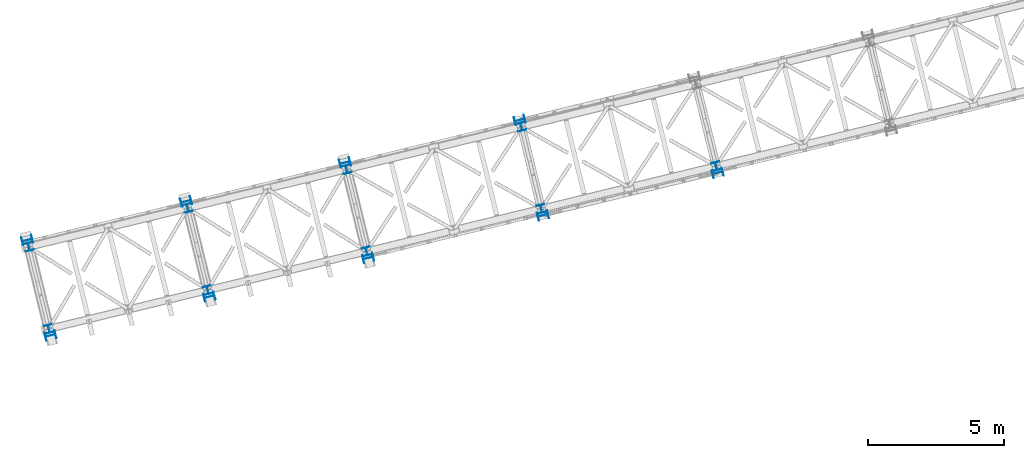
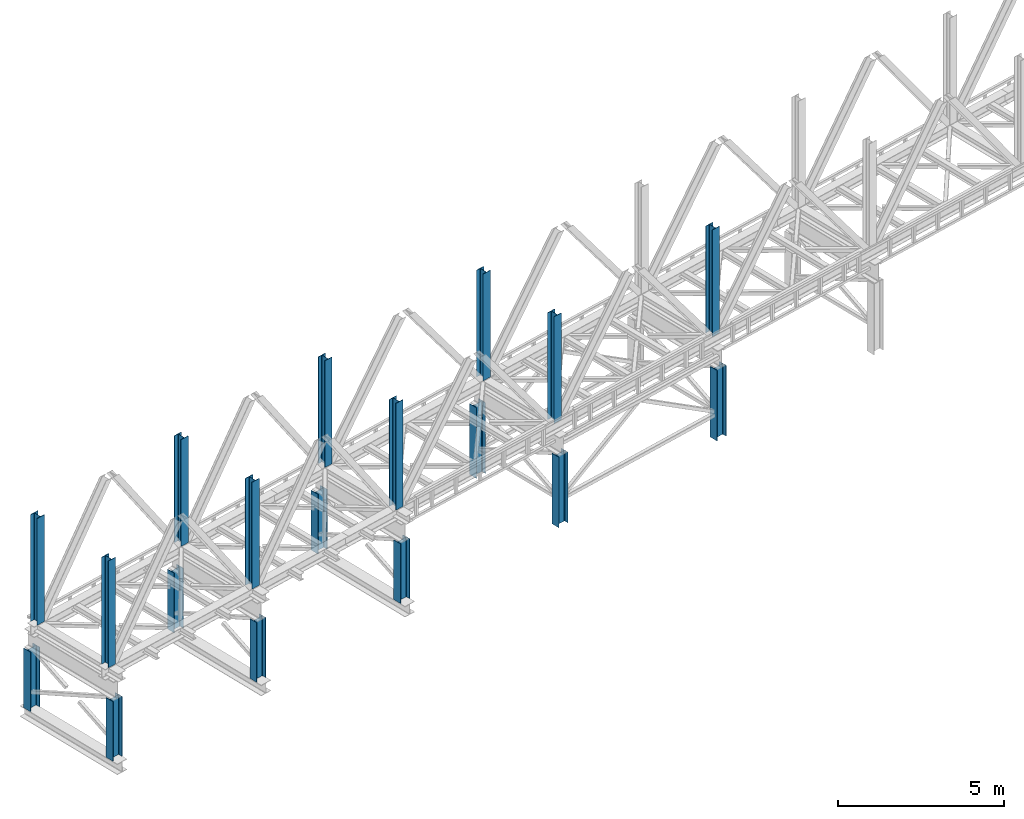
# One storey, part 1 of 92: 18 columns.
"""IFC4 building model written with IfcOpenShell, lengths in millimetres."""

import ifcopenshell
import ifcopenshell.guid

model = None  # the IFC model being written
_history = None  # IfcOwnerHistory: only IFC2X3 demands one
_inside = {}  # id of a spatial element -> (the spatial element, [elements in it])
_under = {}  # id of a project, library or spatial element -> (it, [spatial elements below it])
_declared = {}  # id of a project -> (the project, [libraries it declares])
_typed = {}  # id of a type object -> (the type object, [elements of that type])
_made_of = {}  # id of a material, layer set ... -> (it, [elements and type objects made of it])


def new_model(schema):
    """Start an empty IFC model of exactly this schema.

    Asked for "IFC4X3", IfcOpenShell would pick the latest addendum, in which some entities
    have other attributes; the version numbers below select the first issue.
    IFC2X3 requires an IfcOwnerHistory on every rooted entity: one is made here for all.
    """
    global model, _history
    if schema == "IFC4X3":
        model = ifcopenshell.file(schema_version=(4, 3, 0, 0))
    else:
        model = ifcopenshell.file(schema=schema)
    _inside.clear()
    _under.clear()
    _declared.clear()
    _typed.clear()
    _made_of.clear()
    _history = None
    if model.schema == "IFC2X3":
        org = make("IfcOrganization", Name="unknown")
        user = make(
            "IfcPersonAndOrganization",
            ThePerson=make("IfcPerson", FamilyName="unknown"),
            TheOrganization=org,
        )
        app = make(
            "IfcApplication",
            ApplicationDeveloper=org,
            Version="unknown",
            ApplicationFullName="unknown",
            ApplicationIdentifier="unknown",
        )
        _history = make(
            "IfcOwnerHistory",
            OwningUser=user,
            OwningApplication=app,
            ChangeAction="ADDED",
            CreationDate=0,
        )
    return model


def make(cls, **values):
    """One entity of the class cls with the attributes given. An attribute that is None is left unset."""
    return model.create_entity(
        cls, **{name: value for name, value in values.items() if value is not None}
    )


def entity(cls, *values):
    """Any entity or typed value of the class cls, its attributes in the order of the schema. None: left unset."""
    e = model.create_entity(cls)
    for i, value in enumerate(values):
        if value is not None:
            e[i] = value
    return e


def rooted(cls, **values):
    """An entity with a GlobalId (a new one), such as an element, a storey or a relation."""
    return make(cls, GlobalId=ifcopenshell.guid.new(), OwnerHistory=_history, **values)


def si_unit(unit_type, name, prefix=None):
    """IfcSIUnit, for example si_unit("LENGTHUNIT", "METRE", prefix="MILLI")."""
    return make("IfcSIUnit", UnitType=unit_type, Prefix=prefix, Name=name)


def converted_unit(unit_type, name, factor, base, dimensions=None, offset=None):
    """IfcConversionBasedUnit, such as the inch: factor (a typed value) times the base unit."""
    return make(
        "IfcConversionBasedUnit"
        if offset is None
        else "IfcConversionBasedUnitWithOffset",
        ConversionOffset=offset,
        Dimensions=None
        if dimensions is None
        else entity("IfcDimensionalExponents", *dimensions),
        UnitType=unit_type,
        Name=name,
        ConversionFactor=make(
            "IfcMeasureWithUnit", ValueComponent=factor, UnitComponent=base
        ),
    )


def derived_unit(unit_type, elements):
    """IfcDerivedUnit: a product of units, each with its exponent."""
    return make(
        "IfcDerivedUnit",
        Elements=[
            make("IfcDerivedUnitElement", Unit=unit, Exponent=power)
            for unit, power in elements
        ],
        UnitType=unit_type,
    )


def assignment(units):
    """IfcUnitAssignment: the units of a project."""
    return None if units is None else make("IfcUnitAssignment", Units=units)


def point(xyz):
    """IfcCartesianPoint."""
    return None if xyz is None else make("IfcCartesianPoint", Coordinates=xyz)


def direction(xyz):
    """IfcDirection."""
    return None if xyz is None else make("IfcDirection", DirectionRatios=xyz)


def frame(location, z_axis=None, x_axis=None):
    """IfcAxis2Placement3D, a coordinate frame: its origin and axes. An axis left out is left unset."""
    return make(
        "IfcAxis2Placement3D",
        Location=point(location),
        Axis=direction(z_axis),
        RefDirection=direction(x_axis),
    )


def origin():
    """The frame at (0, 0, 0) with its axes left unset."""
    return frame((0.0, 0.0, 0.0))


def place(relative_to, where):
    """IfcLocalPlacement: puts the frame where relative to a parent placement (None: the world)."""
    return make(
        "IfcLocalPlacement", PlacementRelTo=relative_to, RelativePlacement=where
    )


def context(
    kind, dimensions, precision=None, world=None, true_north=None, identifier=None
):
    """IfcGeometricRepresentationContext, for example the 3D "Model" context."""
    return make(
        "IfcGeometricRepresentationContext",
        ContextIdentifier=identifier,
        ContextType=kind,
        CoordinateSpaceDimension=dimensions,
        Precision=precision,
        WorldCoordinateSystem=world,
        TrueNorth=true_north,
    )


def subcontext(parent, identifier, kind, view, scale=None):
    """IfcGeometricRepresentationSubContext, for example "Body" below "Model"."""
    return make(
        "IfcGeometricRepresentationSubContext",
        ContextIdentifier=identifier,
        ContextType=kind,
        ParentContext=parent,
        TargetScale=scale,
        TargetView=view,
    )


def project(units=None, contexts=None):
    """IfcProject with its units and contexts."""
    return rooted(
        "IfcProject",
        Name="project",
        RepresentationContexts=contexts,
        UnitsInContext=assignment(units),
    )


def spatial(cls, under=None, at=None, **own):
    """A site, building, storey or space (cls), placed at a placement, below another one or the project."""
    s = rooted(cls, ObjectPlacement=at, **own)
    if under is not None:
        _under.setdefault(under.id(), (under, []))[1].append(s)
    return s


def point_list(points):
    """IfcCartesianPointList2D or 3D."""
    cls = (
        "IfcCartesianPointList2D" if len(points[0]) == 2 else "IfcCartesianPointList3D"
    )
    return make(cls, CoordList=points)


def indexed_curve(points, segments=None, self_intersect=None):
    """IfcIndexedPolyCurve: lines and arcs through numbered points (the first is 1)."""
    return make(
        "IfcIndexedPolyCurve",
        Points=point_list(points),
        Segments=segments,
        SelfIntersect=self_intersect,
    )


def outline(outer, holes=None, kind="AREA"):
    """IfcArbitraryClosedProfileDef: a profile drawn as a closed curve; with holes, ...WithVoids."""
    if holes is None:
        return make("IfcArbitraryClosedProfileDef", ProfileType=kind, OuterCurve=outer)
    return make(
        "IfcArbitraryProfileDefWithVoids",
        ProfileType=kind,
        OuterCurve=outer,
        InnerCurves=holes,
    )


def extrude(swept, where, along, depth):
    """IfcExtrudedAreaSolid: the profile swept, set in the frame where, extruded along a direction by depth."""
    return make(
        "IfcExtrudedAreaSolid",
        SweptArea=swept,
        Position=where,
        ExtrudedDirection=direction(along),
        Depth=depth,
    )


def shape(context_of_items, identifier, shape_type, items):
    """IfcShapeRepresentation: the items that make up one representation, for example the "Body"."""
    return make(
        "IfcShapeRepresentation",
        ContextOfItems=context_of_items,
        RepresentationIdentifier=identifier,
        RepresentationType=shape_type,
        Items=items,
    )


def made_of(thing, what):
    """Note that an element or type object is made of a material, layer set ...; save() writes the relation."""
    if what is not None:
        _made_of.setdefault(what.id(), (what, []))[1].append(thing)
    return thing


def type_object(cls, material=None, **own):
    """A type object (cls), such as IfcWallType, which elements share."""
    return made_of(rooted(cls, **own), material)


def element(
    cls,
    number,
    at=None,
    inside=None,
    cuts=None,
    type_object=None,
    material=None,
    context=None,
    identifier="Body",
    shape_type=None,
    held_by="IfcProductDefinitionShape",
    body=None,
    shapes=None,
    **own,
):
    """One element of the class cls, such as IfcWall. Its Tag is "e" and its number.

    at: its placement. inside: the storey or other place that contains it. cuts: it is an
    opening in that element (IfcRelVoidsElement). A single representation is given by context,
    identifier, shape_type and body (its items); several are given by shapes. held_by: the class
    of the entity that holds the representations. save() writes the other relations.
    """
    e = rooted(cls, Tag="e%d" % number, ObjectPlacement=at, **own)
    if body is not None:
        shapes = [shape(context, identifier, shape_type, body)]
    if shapes is not None:
        e.Representation = make(held_by, Representations=shapes)
    if inside is not None:
        _inside.setdefault(inside.id(), (inside, []))[1].append(e)
    if cuts is not None:
        rooted(
            "IfcRelVoidsElement", RelatingBuildingElement=cuts, RelatedOpeningElement=e
        )
    if type_object is not None:
        _typed.setdefault(type_object.id(), (type_object, []))[1].append(e)
    return made_of(e, material)


def aggregate(whole, parts):
    """IfcRelAggregates: a whole, such as a stair, and the parts it consists of."""
    return rooted("IfcRelAggregates", RelatingObject=whole, RelatedObjects=parts)


def save(model, path):
    """Write the relations noted so far, then the file.

    IfcRelAggregates (storeys below a building ...), IfcRelContainedInSpatialStructure (elements
    in a storey), IfcRelDefinesByType, IfcRelAssociatesMaterial and IfcRelDeclares: one each for
    every whole, place, type object, material and project.
    """
    for whole, parts in _under.values():
        aggregate(whole, parts)
    for where, things in _inside.values():
        rooted(
            "IfcRelContainedInSpatialStructure",
            RelatedElements=things,
            RelatingStructure=where,
        )
    for kind, things in _typed.values():
        rooted("IfcRelDefinesByType", RelatedObjects=things, RelatingType=kind)
    for what, things in _made_of.values():
        rooted("IfcRelAssociatesMaterial", RelatedObjects=things, RelatingMaterial=what)
    for by, libraries in _declared.values():
        rooted("IfcRelDeclares", RelatingContext=by, RelatedDefinitions=libraries)
    model.write(path)


model = new_model("IFC4")

# Units and contexts
model_context = context("Model", 3, precision=0.01, world=origin(), true_north=direction((6.12303176911189e-17, 1.0)))
plan_context = context("Plan", 3, precision=0.01, world=origin(), true_north=direction((6.12303176911189e-17, 1.0)))
body_context = subcontext(model_context, "Body", "Model", "MODEL_VIEW")
ifc_project = project(units=[si_unit("LENGTHUNIT", "METRE", prefix="MILLI"), si_unit("AREAUNIT", "SQUARE_METRE"), si_unit("VOLUMEUNIT", "CUBIC_METRE"), converted_unit("PLANEANGLEUNIT", "DEGREE", entity("IfcRatioMeasure", 0.0174532925199433), si_unit("PLANEANGLEUNIT", "RADIAN"), dimensions=[0, 0, 0, 0, 0, 0, 0]), si_unit("MASSUNIT", "GRAM", prefix="KILO"), derived_unit("MASSDENSITYUNIT", [(si_unit("MASSUNIT", "GRAM", prefix="KILO"), 1), (si_unit("LENGTHUNIT", "METRE"), -3)]), derived_unit("MOMENTOFINERTIAUNIT", [(si_unit("LENGTHUNIT", "METRE"), 4)]), si_unit("TIMEUNIT", "SECOND"), si_unit("FREQUENCYUNIT", "HERTZ"), si_unit("THERMODYNAMICTEMPERATUREUNIT", "DEGREE_CELSIUS"), derived_unit("THERMALTRANSMITTANCEUNIT", [(si_unit("MASSUNIT", "GRAM", prefix="KILO"), 1), (si_unit("THERMODYNAMICTEMPERATUREUNIT", "KELVIN"), -1), (si_unit("TIMEUNIT", "SECOND"), -3)]), derived_unit("VOLUMETRICFLOWRATEUNIT", [(si_unit("LENGTHUNIT", "METRE"), 3), (si_unit("TIMEUNIT", "SECOND"), -1)]), derived_unit("MASSFLOWRATEUNIT", [(si_unit("MASSUNIT", "GRAM", prefix="KILO"), 1), (si_unit("TIMEUNIT", "SECOND"), -1)]), derived_unit("ROTATIONALFREQUENCYUNIT", [(si_unit("TIMEUNIT", "SECOND"), -1)]), si_unit("ELECTRICCURRENTUNIT", "AMPERE"), si_unit("ELECTRICVOLTAGEUNIT", "VOLT"), si_unit("POWERUNIT", "WATT"), si_unit("FORCEUNIT", "NEWTON", prefix="KILO"), si_unit("ILLUMINANCEUNIT", "LUX"), si_unit("LUMINOUSFLUXUNIT", "LUMEN"), si_unit("LUMINOUSINTENSITYUNIT", "CANDELA"), derived_unit("USERDEFINED", [(si_unit("MASSUNIT", "GRAM", prefix="KILO"), -1), (si_unit("LENGTHUNIT", "METRE"), -2), (si_unit("TIMEUNIT", "SECOND"), 3), (si_unit("LUMINOUSFLUXUNIT", "LUMEN"), 1)]), derived_unit("LINEARVELOCITYUNIT", [(si_unit("LENGTHUNIT", "METRE"), 1), (si_unit("TIMEUNIT", "SECOND"), -1)]), si_unit("PRESSUREUNIT", "PASCAL"), derived_unit("USERDEFINED", [(si_unit("LENGTHUNIT", "METRE"), -2), (si_unit("MASSUNIT", "GRAM", prefix="KILO"), 1), (si_unit("TIMEUNIT", "SECOND"), -2)]), derived_unit("LINEARFORCEUNIT", [(si_unit("MASSUNIT", "GRAM", prefix="KILO"), 1), (si_unit("LENGTHUNIT", "METRE"), 1), (si_unit("TIMEUNIT", "SECOND"), -2), (si_unit("LENGTHUNIT", "METRE"), -1)]), derived_unit("PLANARFORCEUNIT", [(si_unit("MASSUNIT", "GRAM", prefix="KILO"), 1), (si_unit("LENGTHUNIT", "METRE"), 1), (si_unit("TIMEUNIT", "SECOND"), -2), (si_unit("LENGTHUNIT", "METRE"), -2)])], contexts=[model_context, plan_context])

# Site, building, storey
site_placement = place(None, origin())
site = spatial("IfcSite", under=ifc_project, at=site_placement, CompositionType="ELEMENT")
building_placement = place(site_placement, origin())
building = spatial("IfcBuilding", under=site, at=building_placement, CompositionType="ELEMENT")
storey_placement = place(building_placement, frame((0.0, 0.0, 15900.0)))
storey = spatial("IfcBuildingStorey", under=building, at=storey_placement, Name="05", CompositionType="ELEMENT", Elevation=15900.0)

# Columns
column_type_1 = type_object("IfcColumnType", PredefinedType="COLUMN")
placement = place(storey_placement, origin())
element("IfcColumn", 1, at=placement, inside=storey, type_object=column_type_1, ObjectType="Steel Column", PredefinedType="COLUMN", context=body_context, shape_type="SweptSolid", body=[
    extrude(outline(indexed_curve([(-196.000000000003, -149.999999999996), (-180.000000000004, -149.999999999996), (-179.999999999999, -27.7499999999967), (-178.325349715252, -19.3309644879636), (-173.556349186109, -12.1936508138919), (-166.419035512033, -7.42465028474881), (-157.999999999999, -5.74999999999698), (157.999999999996, -5.75000000000311), (166.419035512028, -7.42465028475528), (173.556349186106, -12.193650813901), (178.325349715245, -19.3309644879716), (180.000000000002, -27.7500000000052), (179.999999999998, -150.000000000004), (195.999999999997, -150.000000000005), (196.000000000003, 149.999999999995), (180.000000000003, 149.999999999995), (179.999999999999, 27.7499999999961), (178.325349715252, 19.3309644879631), (173.5563491861, 12.193650813893), (166.419035512032, 7.4246502847467), (157.999999999999, 5.74999999999646), (-157.999999999997, 5.75000000000206), (-166.419035512028, 7.4246502847537), (-173.556349186115, 12.1936508139025), (-178.325349715245, 19.3309644879711), (-180.000000000002, 27.7500000000047), (-179.999999999998, 150.000000000003), (-195.999999999997, 150.000000000004), (-196.000000000003, -149.999999999996)], self_intersect=False)), frame((-60216.44, 2665.86, 398.0), z_axis=(0.0, 0.0, 1.0), x_axis=(-0.971552058141468, -0.236826092990358, 0.0)), (0.0, 0.0, 1.0), 2197.00000000001),
])
column_type_2 = type_object("IfcColumnType", PredefinedType="COLUMN")
element("IfcColumn", 2, at=placement, inside=storey, type_object=column_type_2, ObjectType="Steel Column", PredefinedType="COLUMN", context=body_context, shape_type="SweptSolid", body=[
    extrude(outline(indexed_curve([(-196.000000000006, -150.0), (-180.000000000007, -150.0), (-180.000000000007, -27.75), (-178.32534971526, -19.3309644879674), (-173.556349186108, -12.1936508138966), (-166.419035512041, -7.42465028475223), (-158.000000000007, -5.75000000000066), (157.999999999988, -5.74999999999533), (166.419035512028, -7.42465028474928), (173.556349186099, -12.1936508138922), (178.325349715238, -19.3309644879637), (179.999999999995, -27.7499999999967), (179.999999999995, -149.999999999996), (195.999999999994, -149.999999999996), (195.99999999999, 150.000000000004), (179.99999999999, 150.000000000003), (179.99999999999, 27.7500000000041), (178.325349715243, 19.3309644879715), (173.5563491861, 12.1936508138987), (166.419035512024, 7.42465028475633), (157.99999999999, 5.75000000000371), (-158.000000000005, 5.75000000000049), (-166.419035512036, 7.42465028475133), (-173.556349186115, 12.1936508138973), (-178.325349715254, 19.3309644879689), (-180.000000000012, 27.7500000000019), (-180.000000000012, 150.0), (-196.000000000011, 150.0), (-196.000000000006, -150.0)], self_intersect=False)), frame((-61069.01, 6163.45, 398.0), z_axis=(0.0, 0.0, 1.0), x_axis=(-0.971552058141476, -0.236826092990326, 0.0)), (0.0, 0.0, 1.0), 2197.0),
])
column_type_3 = type_object("IfcColumnType", PredefinedType="COLUMN")
element("IfcColumn", 3, at=placement, inside=storey, type_object=column_type_3, ObjectType="Steel Column", PredefinedType="COLUMN", context=body_context, shape_type="SweptSolid", body=[
    extrude(outline(indexed_curve([(-196.000000000003, -149.999999999995), (-180.000000000003, -149.999999999995), (-179.999999999999, -27.7499999999956), (-178.325349715252, -19.3309644879631), (-173.556349186109, -12.1936508138909), (-166.419035512032, -7.42465028474775), (-157.999999999999, -5.74999999999646), (158.000000000005, -5.75000000000358), (166.419035512028, -7.42465028475423), (173.556349186107, -12.1936508138999), (178.325349715246, -19.3309644879706), (180.000000000003, -27.7500000000042), (179.999999999998, -150.000000000003), (195.999999999998, -150.000000000003), (196.000000000003, 149.999999999996), (180.000000000004, 149.999999999996), (179.999999999999, 27.7499999999972), (178.325349715252, 19.3309644879641), (173.5563491861, 12.193650813894), (166.419035512032, 7.42465028474775), (157.999999999999, 5.74999999999751), (-157.999999999996, 5.75000000000258), (-166.419035512028, 7.42465028475423), (-173.556349186106, 12.1936508139015), (-178.325349715245, 19.3309644879721), (-180.000000000002, 27.7500000000047), (-179.999999999998, 150.000000000004), (-195.999999999997, 150.000000000004), (-196.000000000003, -149.999999999995)], self_intersect=False)), frame((-54387.12, 4086.82, 398.0), z_axis=(0.0, 0.0, 1.0), x_axis=(-0.971552058141468, -0.236826092990358, 0.0)), (0.0, 0.0, 1.0), 2197.00000000001),
])
column_type_4 = type_object("IfcColumnType", PredefinedType="COLUMN")
element("IfcColumn", 4, at=placement, inside=storey, type_object=column_type_4, ObjectType="Steel Column", PredefinedType="COLUMN", context=body_context, shape_type="SweptSolid", body=[
    extrude(outline(indexed_curve([(-195.999999999982, -150.000000000009), (-179.999999999982, -150.000000000008), (-179.999999999982, -27.7500000000083), (-178.325349715235, -19.3309644879757), (-173.556349186092, -12.1936508139028), (-166.419035512016, -7.42465028476049), (-157.999999999982, -5.75000000000891), (158.000000000021, -5.75000000000564), (166.419035512044, -7.42465028475549), (173.556349186123, -12.1936508139004), (178.325349715262, -19.330964487972), (180.00000000002, -27.750000000005), (180.000000000019, -150.000000000004), (196.000000000019, -150.000000000004), (196.000000000014, 149.999999999996), (180.000000000015, 149.999999999995), (180.000000000015, 27.7499999999959), (178.325349715268, 19.3309644879632), (173.556349186116, 12.1936508138925), (166.419035512049, 7.42465028474807), (158.000000000015, 5.74999999999545), (-157.999999999981, 5.74999999998907), (-166.41903551202, 7.42465028474407), (-173.556349186091, 12.193650813888), (-178.325349715238, 19.3309644879605), (-179.999999999987, 27.7499999999926), (-179.999999999987, 149.999999999991), (-195.999999999986, 149.999999999991), (-195.999999999982, -150.000000000009)], self_intersect=False)), frame((-55239.7, 7584.41, 398.0), z_axis=(0.0, 0.0, 1.0), x_axis=(-0.971552058141476, -0.236826092990326, 0.0)), (0.0, 0.0, 1.0), 2197.0),
])
column_type_5 = type_object("IfcColumnType", PredefinedType="COLUMN")
element("IfcColumn", 5, at=placement, inside=storey, type_object=column_type_5, ObjectType="Steel Column", PredefinedType="COLUMN", context=body_context, shape_type="SweptSolid", body=[
    extrude(outline(indexed_curve([(-196.000000000008, -149.99999999999), (-180.000000000009, -149.99999999999), (-180.0, -27.7499999999913), (-178.325349715253, -19.3309644879588), (-173.556349186109, -12.1936508138862), (-166.419035512033, -7.42465028474332), (-157.999999999999, -5.74999999999335), (157.999999999996, -5.75000000000884), (166.419035512027, -7.42465028476128), (173.556349186106, -12.1936508139067), (178.325349715245, -19.3309644879775), (179.999999999993, -27.7500000000096), (179.999999999993, -150.000000000012), (195.999999999992, -150.000000000012), (196.000000000008, 149.999999999988), (180.000000000008, 149.999999999988), (180.0, 27.7499999999892), (178.325349715253, 19.3309644879567), (173.556349186109, 12.1936508138852), (166.419035512032, 7.42465028474122), (157.999999999998, 5.74999999999019), (-157.999999999996, 5.75000000000779), (-166.419035512028, 7.42465028475707), (-173.556349186106, 12.1936508139056), (-178.325349715245, 19.3309644879764), (-180.000000000002, 27.7500000000106), (-179.999999999993, 150.000000000011), (-195.999999999993, 150.00000000001), (-196.000000000008, -149.99999999999)], self_intersect=False)), frame((-48557.81, 5507.78, 398.0), z_axis=(0.0, 0.0, 1.0), x_axis=(-0.97155205814146, -0.23682609299039, 0.0)), (0.0, 0.0, 1.0), 2197.00000000001),
])
column_type_6 = type_object("IfcColumnType", PredefinedType="COLUMN")
element("IfcColumn", 6, at=placement, inside=storey, type_object=column_type_6, ObjectType="Steel Column", PredefinedType="COLUMN", context=body_context, shape_type="SweptSolid", body=[
    extrude(outline(indexed_curve([(-196.000000000007, -150.000000000001), (-180.000000000007, -150.000000000001), (-180.000000000007, -27.7500000000011), (-178.32534971526, -19.3309644879685), (-173.556349186117, -12.1936508138956), (-166.419035512041, -7.42465028475328), (-158.000000000007, -5.75000000000066), (157.999999999988, -5.74999999999744), (166.419035512019, -7.42465028474828), (173.556349186098, -12.1936508138932), (178.325349715237, -19.3309644879648), (179.999999999995, -27.7499999999967), (179.999999999994, -149.999999999997), (195.999999999994, -149.999999999997), (195.999999999989, 150.000000000002), (179.99999999999, 150.000000000003), (179.99999999999, 27.7500000000041), (178.325349715234, 19.3309644879725), (173.556349186091, 12.1936508138997), (166.419035512024, 7.42465028475528), (157.99999999999, 5.75000000000266), (-158.000000000005, 5.74999999999838), (-166.419035512045, 7.42465028475233), (-173.556349186116, 12.1936508138963), (-178.325349715254, 19.3309644879678), (-180.000000000012, 27.7499999999998), (-180.000000000012, 149.999999999999), (-196.000000000011, 149.999999999999), (-196.000000000007, -150.000000000001)], self_intersect=False)), frame((-49410.39, 9005.36, 398.0), z_axis=(0.0, 0.0, 1.0), x_axis=(-0.971552058141476, -0.236826092990326, 0.0)), (0.0, 0.0, 1.0), 2197.0),
])
column_type_7 = type_object("IfcColumnType", PredefinedType="COLUMN")
element("IfcColumn", 7, at=placement, inside=storey, type_object=column_type_7, ObjectType="Steel Column", PredefinedType="COLUMN", context=body_context, shape_type="SweptSolid", body=[
    extrude(outline(indexed_curve([(-196.000000000007, -150.000000000002), (-180.000000000008, -150.000000000002), (-180.000000000007, -27.7500000000032), (-178.325349715252, -19.3309644879715), (-173.556349186109, -12.1936508138987), (-166.419035512041, -7.42465028475433), (-158.000000000008, -5.75000000000275), (157.999999999996, -5.75000000000055), (166.419035512027, -7.42465028475138), (173.556349186098, -12.1936508138953), (178.325349715237, -19.3309644879658), (179.999999999994, -27.7499999999989), (179.999999999994, -149.999999999998), (195.999999999993, -149.999999999999), (195.999999999989, 150.000000000001), (179.99999999999, 150.000000000002), (179.999999999998, 27.75), (178.325349715242, 19.3309644879683), (173.556349186099, 12.1936508138955), (166.419035512023, 7.42465028475317), (157.999999999989, 5.7500000000016), (-158.000000000014, 5.74999999999939), (-166.419035512037, 7.42465028474713), (-173.556349186116, 12.1936508138931), (-178.325349715264, 19.3309644879657), (-180.000000000013, 27.7499999999966), (-180.000000000012, 149.999999999997), (-196.000000000011, 149.999999999998), (-196.000000000007, -150.000000000002)], self_intersect=False)), frame((-42145.56, 7070.83, -1.99), z_axis=(0.0, 0.0, 1.0), x_axis=(-0.971552058141476, -0.236826092990326, 0.0)), (0.0, 0.0, 1.0), 2595.99999999999),
])
column_type_8 = type_object("IfcColumnType", PredefinedType="COLUMN")
element("IfcColumn", 8, at=placement, inside=storey, type_object=column_type_8, ObjectType="Steel Column", PredefinedType="COLUMN", context=body_context, shape_type="SweptSolid", body=[
    extrude(outline(indexed_curve([(-195.999999999981, -150.000000000007), (-179.999999999982, -150.000000000007), (-179.999999999982, -27.7500000000072), (-178.325349715235, -19.3309644879746), (-173.556349186092, -12.1936508139018), (-166.419035512016, -7.42465028475944), (-157.999999999982, -5.75000000000681), (158.000000000021, -5.75000000000564), (166.419035512045, -7.42465028475443), (173.556349186124, -12.1936508138994), (178.325349715262, -19.330964487972), (180.000000000011, -27.7500000000029), (180.00000000002, -150.000000000003), (196.000000000019, -150.000000000003), (196.000000000015, 149.999999999997), (180.000000000015, 149.999999999995), (180.000000000015, 27.7499999999969), (178.32534971526, 19.3309644879663), (173.556349186125, 12.1936508138914), (166.419035512049, 7.42465028474913), (158.000000000015, 5.7499999999965), (-157.99999999998, 5.74999999999118), (-166.41903551202, 7.42465028474617), (-173.556349186091, 12.193650813887), (-178.32534971523, 19.3309644879595), (-179.999999999987, 27.7499999999926), (-179.999999999987, 149.999999999993), (-195.999999999986, 149.999999999993), (-195.999999999981, -150.000000000007)], self_intersect=False)), frame((-42998.14, 10568.42, -2.0), z_axis=(0.0, 0.0, 1.0), x_axis=(-0.971552058141476, -0.236826092990326, 0.0)), (0.0, 0.0, 1.0), 2597.00000000003),
])
column_type_9 = type_object("IfcColumnType", PredefinedType="COLUMN")
element("IfcColumn", 9, at=placement, inside=storey, type_object=column_type_9, ObjectType="Steel Column", PredefinedType="COLUMN", context=body_context, shape_type="SweptSolid", body=[
    extrude(outline(indexed_curve([(-196.000000000007, -150.000000000002), (-179.999999999999, -150.000000000002), (-180.000000000003, -27.7500000000015), (-178.325349715252, -19.3309644879699), (-173.556349186109, -12.1936508138971), (-166.419035512037, -7.4246502847527), (-158.000000000007, -5.75000000000118), (157.999999999996, -5.74999999999896), (166.419035512028, -7.42465028475089), (173.556349186103, -12.1936508138948), (178.325349715246, -19.3309644879664), (179.999999999995, -27.7499999999984), (179.999999999994, -149.999999999999), (196.000000000002, -149.999999999999), (195.999999999999, 150.000000000002), (179.99999999999, 150.000000000002), (179.999999999994, 27.7500000000014), (178.325349715243, 19.3309644879698), (173.5563491861, 12.193650813897), (166.419035512028, 7.42465028475265), (157.999999999994, 5.7500000000011), (-158.000000000005, 5.74999999999997), (-166.419035512036, 7.42465028475294), (-173.556349186107, 12.1936508138948), (-178.325349715254, 19.3309644879684), (-180.000000000008, 27.7499999999994), (-180.000000000002, 150.000000000001), (-196.000000000011, 149.999999999999), (-196.000000000007, -150.000000000002)], self_intersect=False)), frame((-35733.32, 8633.88, -1.99), z_axis=(0.0, 0.0, 1.0), x_axis=(-0.971552058141475, -0.23682609299033, 0.0)), (0.0, 0.0, 1.0), 2596.99999999999),
])
column_type_10 = type_object("IfcColumnType", PredefinedType="COLUMN")
element("IfcColumn", 10, at=placement, inside=storey, type_object=column_type_10, ObjectType="Steel Column", PredefinedType="COLUMN", context=body_context, shape_type="SweptSolid", body=[
    extrude(outline(indexed_curve([(-149.999999999947, -150.00000000004), (-134.499999999948, -150.00000000004), (-134.499999999989, -23.000000000035), (-133.129831585195, -16.1116982174633), (-129.227922061352, -10.2720779386778), (-123.388301782567, -6.37016841483106), (-116.499999999995, -5.00000000002753), (116.500000000005, -4.99999999995134), (123.388301782576, -6.37016841475037), (129.227922061364, -10.2720779385883), (133.129831585211, -16.1116982173765), (134.500000000009, -22.9999999999507), (134.500000000052, -149.999999999947), (150.000000000053, -149.999999999939), (149.999999999952, 150.000000000057), (134.499999999953, 150.000000000057), (134.499999999994, 23.0000000000515), (133.1298315852, 16.11169821748), (129.227922061357, 10.2720779386945), (123.388301782573, 6.37016841484763), (116.5, 5.0000000000441), (-116.499999999999, 4.99999999996792), (-123.388301782572, 6.3701684147584), (-129.227922061359, 10.272077938605), (-133.129831585207, 16.1116982173846), (-134.500000000006, 22.9999999999588), (-134.500000000047, 149.999999999964), (-150.000000000048, 149.999999999956), (-149.999999999947, -150.00000000004)], self_intersect=False)), frame((-60275.64, 2908.75, 3685.0), z_axis=(0.0, 0.0, 1.0), x_axis=(-0.236826092990013, 0.971552058141552, 0.0)), (0.0, 0.0, 1.0), 3931.00000000001),
])
column_type_11 = type_object("IfcColumnType", PredefinedType="COLUMN")
element("IfcColumn", 11, at=placement, inside=storey, type_object=column_type_11, ObjectType="Steel Column", PredefinedType="COLUMN", context=body_context, shape_type="SweptSolid", body=[
    extrude(outline(indexed_curve([(-149.999999999951, -150.000000000048), (-134.499999999952, -150.000000000048), (-134.499999999993, -23.0000000000429), (-133.129831585199, -16.1116982174712), (-129.227922061356, -10.2720779386857), (-123.388301782572, -6.37016841483897), (-116.499999999999, -5.00000000003544), (116.5, -4.99999999995924), (123.388301782572, -6.37016841475827), (129.22792206136, -10.2720779385963), (133.129831585206, -16.1116982173844), (134.500000000005, -22.9999999999586), (134.500000000048, -149.999999999955), (150.000000000049, -149.999999999947), (149.999999999948, 150.000000000049), (134.499999999949, 150.000000000049), (134.49999999999, 23.0000000000436), (133.129831585196, 16.111698217472), (129.227922061353, 10.2720779386865), (123.388301782569, 6.37016841483961), (116.499999999996, 5.00000000003607), (-116.500000000003, 4.99999999995975), (-123.388301782576, 6.37016841475036), (-129.227922061362, 10.2720779385968), (-133.129831585211, 16.1116982173766), (-134.500000000009, 22.9999999999507), (-134.500000000048, 149.999999999964), (-150.000000000052, 149.999999999948), (-149.999999999951, -150.000000000048)], self_intersect=False)), frame((-54446.33, 4329.71, 3685.0), z_axis=(0.0, 0.0, 1.0), x_axis=(-0.236826092990013, 0.971552058141552, 0.0)), (0.0, 0.0, 1.0), 3931.00000000001),
])
column_type_12 = type_object("IfcColumnType", PredefinedType="COLUMN")
element("IfcColumn", 12, at=placement, inside=storey, type_object=column_type_12, ObjectType="Steel Column", PredefinedType="COLUMN", context=body_context, shape_type="SweptSolid", body=[
    extrude(outline(indexed_curve([(-150.000000000031, -149.999999999977), (-134.50000000003, -149.999999999977), (-134.500000000005, -22.9999999999802), (-133.129831585207, -16.1116982174091), (-129.227922061359, -10.2720779386173), (-123.388301782573, -6.37016841477337), (-116.500000000001, -4.99999999998207), (116.499999999999, -5.00000000003072), (123.38830178257, -6.37016841482463), (129.227922061355, -10.2720779386745), (133.1298315852, -16.1116982174562), (134.499999999995, -23.0000000000312), (134.49999999997, -150.000000000028), (149.999999999969, -150.000000000036), (150.00000000003, 149.999999999968), (134.500000000029, 149.999999999968), (134.500000000006, 22.999999999971), (133.129831585206, 16.1116982174004), (129.227922061359, 10.2720779386083), (123.388301782573, 6.37016841477337), (116.5, 4.99999999997339), (-116.500000000001, 5.00000000001338), (-123.388301782574, 6.3701684148078), (-129.227922061357, 10.2720779386571), (-133.129831585203, 16.1116982174391), (-134.499999999998, 23.0000000000141), (-134.499999999969, 150.000000000027), (-149.99999999997, 150.000000000027), (-150.000000000031, -149.999999999977)], self_intersect=False)), frame((-48617.02, 5750.66, 3685.0), z_axis=(0.0, 0.0, 1.0), x_axis=(-0.236826092990533, 0.971552058141425, 0.0)), (0.0, 0.0, 1.0), 3931.00000000001),
])
column_type_13 = type_object("IfcColumnType", PredefinedType="COLUMN")
element("IfcColumn", 13, at=placement, inside=storey, type_object=column_type_13, ObjectType="Steel Column", PredefinedType="COLUMN", context=body_context, shape_type="SweptSolid", body=[
    extrude(outline(indexed_curve([(-150.000000000024, -149.999999999952), (-134.500000000023, -149.999999999952), (-134.499999999998, -22.9999999999549), (-133.1298315852, -16.1116982173841), (-129.227922061354, -10.2720779386007), (-123.388301782568, -6.3701684147568), (-116.499999999994, -4.99999999995708), (116.500000000005, -5.00000000000547), (123.388301782577, -6.37016841479963), (129.227922061363, -10.2720779386495), (133.129831585206, -16.1116982174396), (134.500000000003, -23.0000000000062), (134.499999999975, -150.000000000011), (149.999999999976, -150.000000000011), (150.000000000036, 149.999999999985), (134.500000000036, 149.999999999993), (134.500000000012, 22.9999999999962), (133.129831585213, 16.1116982174254), (129.227922061365, 10.2720779386336), (123.388301782578, 6.37016841478995), (116.500000000008, 4.99999999999839), (-116.499999999994, 5.00000000003837), (-123.388301782566, 6.37016841483253), (-129.227922061352, 10.2720779386826), (-133.129831585197, 16.1116982174643), (-134.499999999989, 23.0000000000475), (-134.499999999963, 150.000000000044), (-149.999999999965, 150.000000000044), (-150.000000000024, -149.999999999952)], self_intersect=False)), frame((-42204.77, 7313.72, 3685.0), z_axis=(0.0, 0.0, 1.0), x_axis=(-0.236826092990533, 0.971552058141425, 0.0)), (0.0, 0.0, 1.0), 3931.00000000001),
])
column_type_14 = type_object("IfcColumnType", PredefinedType="COLUMN")
element("IfcColumn", 14, at=placement, inside=storey, type_object=column_type_14, ObjectType="Steel Column", PredefinedType="COLUMN", context=body_context, shape_type="SweptSolid", body=[
    extrude(outline(indexed_curve([(-149.99999999999, -150.000000000002), (-134.499999999991, -150.000000000002), (-134.499999999998, -23.0000000000013), (-133.129831585201, -16.1116982174301), (-129.227922061357, -10.2720779386457), (-123.388301782571, -6.37016841480061), (-116.499999999998, -4.99999999999888), (116.500000000001, -4.99999999998789), (123.388301782573, -6.37016841478476), (129.22792206136, -10.2720779386286), (133.129831585204, -16.1116982174178), (134.500000000002, -22.9999999999882), (134.500000000009, -149.999999999989), (150.000000000008, -149.999999999989), (149.999999999993, 150.000000000015), (134.499999999992, 150.000000000011), (134.5, 23.0000000000097), (133.129831585203, 16.1116982174385), (129.227922061359, 10.2720779386541), (123.388301782573, 6.37016841480903), (116.5, 5.00000000000729), (-116.499999999999, 5.00000000000078), (-123.388301782568, 6.37016841479687), (-129.227922061358, 10.2720779386415), (-133.129831585203, 16.111698217422), (-134.5, 23.0000000000011), (-134.500000000006, 150.000000000002), (-150.000000000007, 149.999999999998), (-149.99999999999, -150.000000000002)], self_intersect=False)), frame((-35792.53, 8876.77, 3685.0), z_axis=(0.0, 0.0, 1.0), x_axis=(-0.236826092990285, 0.971552058141486, 0.0)), (0.0, 0.0, 1.0), 3931.00000000001),
])
column_type_15 = type_object("IfcColumnType", PredefinedType="COLUMN")
element("IfcColumn", 15, at=placement, inside=storey, type_object=column_type_15, ObjectType="Steel Column", PredefinedType="COLUMN", context=body_context, shape_type="SweptSolid", body=[
    extrude(outline(indexed_curve([(-149.999999999947, -150.000000000039), (-134.499999999949, -150.000000000039), (-134.499999999988, -23.0000000000341), (-133.129831585195, -16.1116982174623), (-129.227922061351, -10.2720779386771), (-123.388301782566, -6.37016841483042), (-116.499999999994, -5.00000000002682), (116.500000000006, -4.99999999995256), (123.388301782576, -6.37016841475152), (129.227922061366, -10.2720779385899), (133.129831585212, -16.1116982173779), (134.50000000001, -22.999999999952), (134.500000000052, -149.999999999949), (150.000000000054, -149.999999999941), (149.999999999955, 150.000000000055), (134.499999999955, 150.000000000055), (134.499999999996, 23.0000000000502), (133.129831585202, 16.1116982174784), (129.227922061359, 10.2720779386929), (123.388301782573, 6.37016841484648), (116.500000000001, 5.00000000004288), (-116.499999999996, 4.99999999997705), (-123.388301782569, 6.37016841476758), (-129.227922061358, 10.2720779386057), (-133.129831585205, 16.111698217394), (-134.500000000003, 22.9999999999683), (-134.500000000045, 149.999999999965), (-150.000000000047, 149.999999999957), (-149.999999999947, -150.000000000039)], self_intersect=False)), frame((-61009.8, 5920.56, 3685.0), z_axis=(0.0, 0.0, 1.0), x_axis=(-0.236826092990021, 0.97155205814155, 0.0)), (0.0, 0.0, 1.0), 3931.00000000001),
])
column_type_16 = type_object("IfcColumnType", PredefinedType="COLUMN")
element("IfcColumn", 16, at=placement, inside=storey, type_object=column_type_16, ObjectType="Steel Column", PredefinedType="COLUMN", context=body_context, shape_type="SweptSolid", body=[
    extrude(outline(indexed_curve([(-149.999999999947, -150.000000000041), (-134.499999999948, -150.000000000041), (-134.49999999999, -23.0000000000358), (-133.129831585195, -16.1116982174643), (-129.227922061353, -10.2720779386788), (-123.388301782568, -6.37016841483195), (-116.499999999996, -5.00000000002824), (116.500000000004, -4.99999999995012), (123.388301782574, -6.37016841474896), (129.227922061364, -10.2720779385872), (133.12983158521, -16.1116982173752), (134.500000000008, -22.9999999999492), (134.500000000053, -149.999999999946), (150.000000000054, -149.999999999938), (149.999999999951, 150.000000000058), (134.499999999951, 150.000000000058), (134.499999999993, 23.0000000000529), (133.1298315852, 16.1116982174811), (129.227922061357, 10.2720779386956), (123.388301782571, 6.37016841484905), (116.499999999999, 5.00000000004533), (-116.499999999998, 4.99999999997563), (-123.388301782571, 6.37016841476605), (-129.22792206136, 10.272077938604), (-133.129831585207, 16.1116982173923), (-134.500000000006, 22.9999999999666), (-134.500000000047, 149.999999999972), (-150.00000000005, 149.999999999955), (-149.999999999947, -150.000000000041)], self_intersect=False)), frame((-55180.49, 7341.52, 3685.0), z_axis=(0.0, 0.0, 1.0), x_axis=(-0.236826092990005, 0.971552058141554, 0.0)), (0.0, 0.0, 1.0), 3931.00000000001),
])
column_type_17 = type_object("IfcColumnType", PredefinedType="COLUMN")
element("IfcColumn", 17, at=placement, inside=storey, type_object=column_type_17, ObjectType="Steel Column", PredefinedType="COLUMN", context=body_context, shape_type="SweptSolid", body=[
    extrude(outline(indexed_curve([(-149.999999999948, -150.000000000059), (-134.499999999949, -150.000000000059), (-134.499999999992, -23.0000000000621), (-133.129831585198, -16.1116982174903), (-129.227922061353, -10.2720779386966), (-123.388301782569, -6.37016841484955), (-116.499999999998, -5.00000000005451), (116.500000000002, -4.99999999997639), (123.388301782573, -6.37016841476656), (129.227922061362, -10.2720779386135), (133.12983158521, -16.1116982173931), (134.500000000009, -22.9999999999673), (134.500000000052, -149.999999999964), (150.000000000051, -149.999999999964), (149.99999999995, 150.00000000004), (134.499999999948, 150.000000000032), (134.499999999993, 23.0000000000351), (133.129831585199, 16.1116982174635), (129.227922061355, 10.2720779386693), (123.388301782571, 6.37016841483118), (116.499999999999, 5.00000000002747), (-116.500000000001, 4.99999999994961), (-123.388301782575, 6.37016841474029), (-129.227922061362, 10.2720779385778), (-133.12983158521, 16.1116982173663), (-134.500000000009, 22.9999999999406), (-134.50000000005, 149.999999999946), (-150.000000000051, 149.999999999937), (-149.999999999948, -150.000000000059)], self_intersect=False)), frame((-49351.18, 8762.48, 3685.0), z_axis=(0.0, 0.0, 1.0), x_axis=(-0.236826092990005, 0.971552058141554, 0.0)), (0.0, 0.0, 1.0), 3931.00000000001),
])
column_type_18 = type_object("IfcColumnType", PredefinedType="COLUMN")
element("IfcColumn", 18, at=placement, inside=storey, type_object=column_type_18, ObjectType="Steel Column", PredefinedType="COLUMN", context=body_context, shape_type="SweptSolid", body=[
    extrude(outline(indexed_curve([(-150.00000000003, -149.999999999955), (-134.500000000031, -149.999999999955), (-134.5, -22.9999999999591), (-133.129831585202, -16.1116982173883), (-129.227922061357, -10.2720779386048), (-123.38830178257, -6.37016841476112), (-116.499999999996, -4.99999999996163), (116.500000000004, -5.00000000001801), (123.388301782576, -6.3701684148124), (129.22792206136, -10.2720779386622), (133.129831585203, -16.1116982174524), (134.5, -23.0000000000191), (134.499999999969, -150.000000000024), (149.99999999997, -150.000000000025), (150.000000000041, 149.999999999971), (134.500000000039, 149.99999999998), (134.500000000011, 22.9999999999833), (133.129831585212, 16.1116982174126), (129.227922061365, 10.2720779386206), (123.388301782577, 6.37016841477745), (116.500000000007, 4.99999999998585), (-116.499999999996, 5.00000000004274), (-123.388301782567, 6.37016841483714), (-129.227922061354, 10.2720779386785), (-133.129831585197, 16.1116982174688), (-134.499999999987, 23.0000000000517), (-134.499999999961, 150.00000000004), (-149.999999999962, 150.000000000041), (-150.00000000003, -149.999999999955)], self_intersect=False)), frame((-42938.93, 10325.53, 3685.0), z_axis=(0.0, 0.0, 1.0), x_axis=(-0.236826092990565, 0.971552058141418, 0.0)), (0.0, 0.0, 1.0), 3931.00000000001),
])

save(model, "model.ifc")
